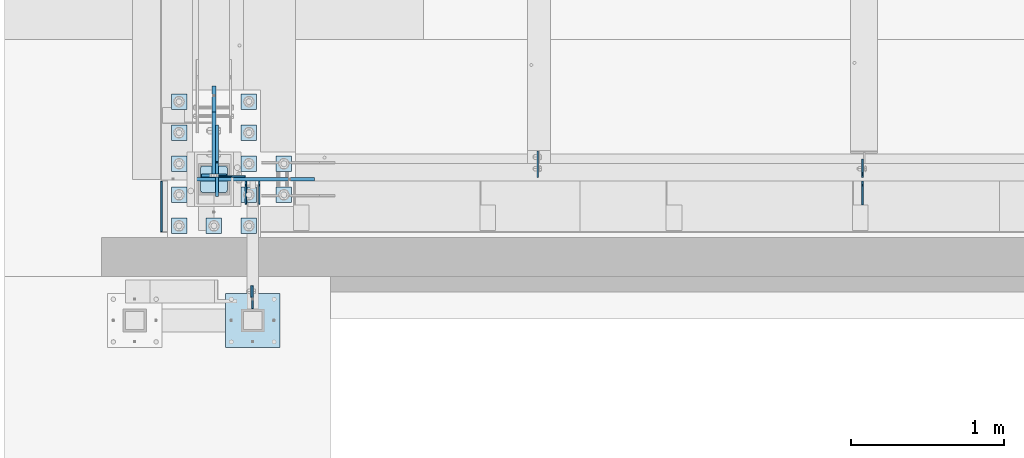
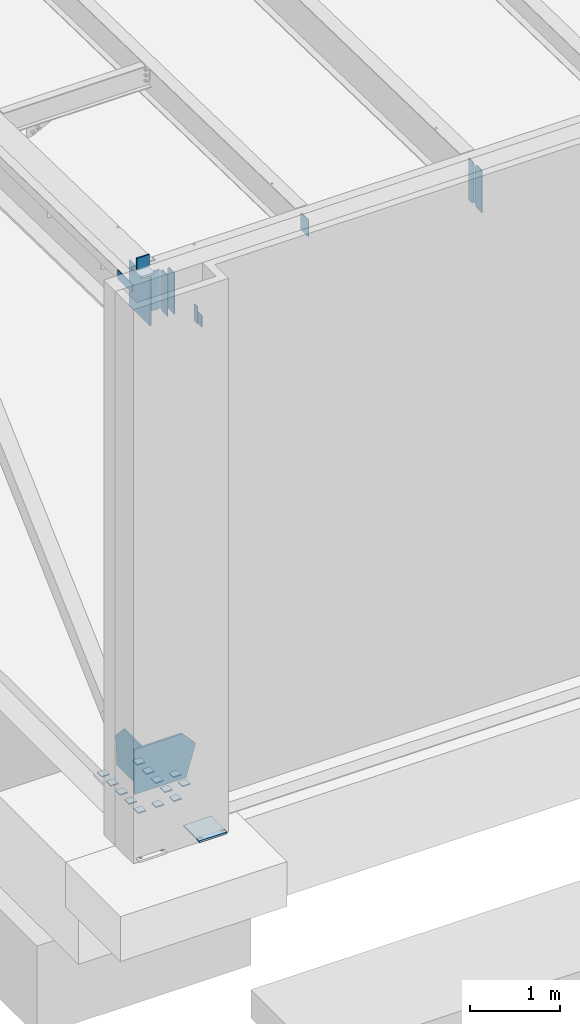
# One storey, part 1426 of 1763: 28 plates, 5 elements without a shape of their own.
"""IFC2X3 building model written with IfcOpenShell, lengths in millimetres."""

import ifcopenshell
import ifcopenshell.guid

model = None  # the IFC model being written
_history = None  # IfcOwnerHistory: only IFC2X3 demands one
_inside = {}  # id of a spatial element -> (the spatial element, [elements in it])
_under = {}  # id of a project, library or spatial element -> (it, [spatial elements below it])
_declared = {}  # id of a project -> (the project, [libraries it declares])
_typed = {}  # id of a type object -> (the type object, [elements of that type])
_made_of = {}  # id of a material, layer set ... -> (it, [elements and type objects made of it])


def new_model(schema):
    """Start an empty IFC model of exactly this schema.

    Asked for "IFC4X3", IfcOpenShell would pick the latest addendum, in which some entities
    have other attributes; the version numbers below select the first issue.
    IFC2X3 requires an IfcOwnerHistory on every rooted entity: one is made here for all.
    """
    global model, _history
    if schema == "IFC4X3":
        model = ifcopenshell.file(schema_version=(4, 3, 0, 0))
    else:
        model = ifcopenshell.file(schema=schema)
    _inside.clear()
    _under.clear()
    _declared.clear()
    _typed.clear()
    _made_of.clear()
    _history = None
    if model.schema == "IFC2X3":
        org = make("IfcOrganization", Name="unknown")
        user = make(
            "IfcPersonAndOrganization",
            ThePerson=make("IfcPerson", FamilyName="unknown"),
            TheOrganization=org,
        )
        app = make(
            "IfcApplication",
            ApplicationDeveloper=org,
            Version="unknown",
            ApplicationFullName="unknown",
            ApplicationIdentifier="unknown",
        )
        _history = make(
            "IfcOwnerHistory",
            OwningUser=user,
            OwningApplication=app,
            ChangeAction="ADDED",
            CreationDate=0,
        )
    return model


def make(cls, **values):
    """One entity of the class cls with the attributes given. An attribute that is None is left unset."""
    return model.create_entity(
        cls, **{name: value for name, value in values.items() if value is not None}
    )


def rooted(cls, **values):
    """An entity with a GlobalId (a new one), such as an element, a storey or a relation."""
    return make(cls, GlobalId=ifcopenshell.guid.new(), OwnerHistory=_history, **values)


def si_unit(unit_type, name, prefix=None):
    """IfcSIUnit, for example si_unit("LENGTHUNIT", "METRE", prefix="MILLI")."""
    return make("IfcSIUnit", UnitType=unit_type, Prefix=prefix, Name=name)


def assignment(units):
    """IfcUnitAssignment: the units of a project."""
    return None if units is None else make("IfcUnitAssignment", Units=units)


def point(xyz):
    """IfcCartesianPoint."""
    return None if xyz is None else make("IfcCartesianPoint", Coordinates=xyz)


def direction(xyz):
    """IfcDirection."""
    return None if xyz is None else make("IfcDirection", DirectionRatios=xyz)


def frame(location, z_axis=None, x_axis=None):
    """IfcAxis2Placement3D, a coordinate frame: its origin and axes. An axis left out is left unset."""
    return make(
        "IfcAxis2Placement3D",
        Location=point(location),
        Axis=direction(z_axis),
        RefDirection=direction(x_axis),
    )


def origin_with_axes():
    """The frame at (0, 0, 0) with the z axis (0, 0, 1) and the x axis (1, 0, 0) written out."""
    return frame((0.0, 0.0, 0.0), z_axis=(0.0, 0.0, 1.0), x_axis=(1.0, 0.0, 0.0))


def place(relative_to, where):
    """IfcLocalPlacement: puts the frame where relative to a parent placement (None: the world)."""
    return make(
        "IfcLocalPlacement", PlacementRelTo=relative_to, RelativePlacement=where
    )


def context(
    kind, dimensions, precision=None, world=None, true_north=None, identifier=None
):
    """IfcGeometricRepresentationContext, for example the 3D "Model" context."""
    return make(
        "IfcGeometricRepresentationContext",
        ContextIdentifier=identifier,
        ContextType=kind,
        CoordinateSpaceDimension=dimensions,
        Precision=precision,
        WorldCoordinateSystem=world,
        TrueNorth=true_north,
    )


def subcontext(parent, identifier, kind, view, scale=None):
    """IfcGeometricRepresentationSubContext, for example "Body" below "Model"."""
    return make(
        "IfcGeometricRepresentationSubContext",
        ContextIdentifier=identifier,
        ContextType=kind,
        ParentContext=parent,
        TargetScale=scale,
        TargetView=view,
    )


def project(units=None, contexts=None):
    """IfcProject with its units and contexts."""
    return rooted(
        "IfcProject",
        Name="project",
        RepresentationContexts=contexts,
        UnitsInContext=assignment(units),
    )


def spatial(cls, under=None, at=None, **own):
    """A site, building, storey or space (cls), placed at a placement, below another one or the project."""
    s = rooted(cls, ObjectPlacement=at, **own)
    if under is not None:
        _under.setdefault(under.id(), (under, []))[1].append(s)
    return s


def faces_of(points, faces, orient=None, outer=None):
    """IfcFace entities. A face is a list of loops; a loop is a list of indices into points, from 0.

    orient and outer hold one flag for each loop. By default every Orientation is true, the
    first loop of a face is its IfcFaceOuterBound and the others are IfcFaceBound.
    """
    made = []
    for i, loops in enumerate(faces):
        bounds = []
        for j, loop in enumerate(loops):
            is_outer = j == 0 if outer is None else outer[i][j]
            bounds.append(
                make(
                    "IfcFaceOuterBound" if is_outer else "IfcFaceBound",
                    Bound=make("IfcPolyLoop", Polygon=[points[k] for k in loop]),
                    Orientation=True if orient is None else orient[i][j],
                )
            )
        made.append(make("IfcFace", Bounds=bounds))
    return made


def faceted_brep(points, faces, orient=None, outer=None, voids=None):
    """IfcFacetedBrep: a solid bounded by flat faces; with voids (closed shells), ...WithVoids."""
    shared = [point(p) for p in points]
    hull = make("IfcClosedShell", CfsFaces=faces_of(shared, faces, orient, outer))
    if voids is None:
        return make("IfcFacetedBrep", Outer=hull)
    return make(
        "IfcFacetedBrepWithVoids",
        Outer=hull,
        Voids=[
            make(cls, CfsFaces=faces_of(shared, fs, o, b)) for cls, fs, o, b in voids
        ],
    )


def shape(context_of_items, identifier, shape_type, items):
    """IfcShapeRepresentation: the items that make up one representation, for example the "Body"."""
    return make(
        "IfcShapeRepresentation",
        ContextOfItems=context_of_items,
        RepresentationIdentifier=identifier,
        RepresentationType=shape_type,
        Items=items,
    )


def material(Name=None, Category=None):
    """IfcMaterial."""
    return make("IfcMaterial", Name=Name, Category=Category)


def made_of(thing, what):
    """Note that an element or type object is made of a material, layer set ...; save() writes the relation."""
    if what is not None:
        _made_of.setdefault(what.id(), (what, []))[1].append(thing)
    return thing


def type_object(cls, material=None, **own):
    """A type object (cls), such as IfcWallType, which elements share."""
    return made_of(rooted(cls, **own), material)


def element(
    cls,
    number,
    at=None,
    inside=None,
    cuts=None,
    type_object=None,
    material=None,
    context=None,
    identifier="Body",
    shape_type=None,
    held_by="IfcProductDefinitionShape",
    body=None,
    shapes=None,
    **own,
):
    """One element of the class cls, such as IfcWall. Its Tag is "e" and its number.

    at: its placement. inside: the storey or other place that contains it. cuts: it is an
    opening in that element (IfcRelVoidsElement). A single representation is given by context,
    identifier, shape_type and body (its items); several are given by shapes. held_by: the class
    of the entity that holds the representations. save() writes the other relations.
    """
    e = rooted(cls, Tag="e%d" % number, ObjectPlacement=at, **own)
    if body is not None:
        shapes = [shape(context, identifier, shape_type, body)]
    if shapes is not None:
        e.Representation = make(held_by, Representations=shapes)
    if inside is not None:
        _inside.setdefault(inside.id(), (inside, []))[1].append(e)
    if cuts is not None:
        rooted(
            "IfcRelVoidsElement", RelatingBuildingElement=cuts, RelatedOpeningElement=e
        )
    if type_object is not None:
        _typed.setdefault(type_object.id(), (type_object, []))[1].append(e)
    return made_of(e, material)


def aggregate(whole, parts):
    """IfcRelAggregates: a whole, such as a stair, and the parts it consists of."""
    return rooted("IfcRelAggregates", RelatingObject=whole, RelatedObjects=parts)


def save(model, path):
    """Write the relations noted so far, then the file.

    IfcRelAggregates (storeys below a building ...), IfcRelContainedInSpatialStructure (elements
    in a storey), IfcRelDefinesByType, IfcRelAssociatesMaterial and IfcRelDeclares: one each for
    every whole, place, type object, material and project.
    """
    for whole, parts in _under.values():
        aggregate(whole, parts)
    for where, things in _inside.values():
        rooted(
            "IfcRelContainedInSpatialStructure",
            RelatedElements=things,
            RelatingStructure=where,
        )
    for kind, things in _typed.values():
        rooted("IfcRelDefinesByType", RelatedObjects=things, RelatingType=kind)
    for what, things in _made_of.values():
        rooted("IfcRelAssociatesMaterial", RelatedObjects=things, RelatingMaterial=what)
    for by, libraries in _declared.values():
        rooted("IfcRelDeclares", RelatingContext=by, RelatedDefinitions=libraries)
    model.write(path)


model = new_model("IFC2X3")

# Units and contexts
model_context = context("Model", 3, precision=1e-05, world=origin_with_axes())
body_context = subcontext(model_context, "Body", "Model", "MODEL_VIEW")
ifc_project = project(units=[si_unit("LENGTHUNIT", "METRE", prefix="MILLI"), si_unit("AREAUNIT", "SQUARE_METRE"), si_unit("VOLUMEUNIT", "CUBIC_METRE"), si_unit("MASSUNIT", "GRAM", prefix="KILO"), si_unit("TIMEUNIT", "SECOND"), si_unit("PLANEANGLEUNIT", "RADIAN"), si_unit("SOLIDANGLEUNIT", "STERADIAN"), si_unit("THERMODYNAMICTEMPERATUREUNIT", "DEGREE_CELSIUS"), si_unit("LUMINOUSINTENSITYUNIT", "LUMEN")], contexts=[model_context])

# Site, building, storey
site_placement = place(None, origin_with_axes())
site = spatial("IfcSite", under=ifc_project, at=site_placement, CompositionType="ELEMENT")
building_placement = place(site_placement, origin_with_axes())
building = spatial("IfcBuilding", under=site, at=building_placement, Name="Undefined", CompositionType="ELEMENT")
storey_placement = place(building_placement, origin_with_axes())
storey = spatial("IfcBuildingStorey", under=building, at=storey_placement, Name="Undefined", CompositionType="ELEMENT", Elevation=0.0)

# Assembly, plate
assembly_1_placement = place(storey_placement, origin_with_axes())
assembly_1 = element("IfcElementAssembly", 1, at=assembly_1_placement, inside=storey, Name="BEAM", AssemblyPlace="NOTDEFINED", PredefinedType="RIGID_FRAME")
ifc_material_1 = material(Name="STEEL/A36")
plate_type_1 = type_object("IfcPlateType", PredefinedType="NOTDEFINED")
plate_1_placement = place(assembly_1_placement, frame((-87131.5061245708, -14487.5249884881, 11849.0999938965), z_axis=(0.0, 0.0, 1.0), x_axis=(0.0, 1.0, 0.0)))
plate_1 = element("IfcPlate", 2, at=plate_1_placement, type_object=plate_type_1, material=ifc_material_1, Name="PLATE", context=body_context, shape_type="Brep", body=[
    faceted_brep([(0.0, -4.76249999999982, 0.0), (-2.83762346953154e-10, -4.7624999996915, 228.600006103516), (-2.83762346953154e-10, 4.76250000028813, 228.600006103517), (0.0, 4.76249999999982, 0.0), (76.1999969480166, -4.76249999961874, 228.600006103516), (76.1999969480166, 4.76250000036089, 228.600006103517), (76.1999969482931, -4.76249999991705, 0.0), (76.1999969482931, 4.76250000006257, 1.81898940354586e-12)], [[[0, 1, 2, 3]], [[1, 4, 5, 2]], [[4, 6, 7, 5]], [[6, 0, 3, 7]], [[5, 7, 3, 2]], [[6, 4, 1, 0]]]),
])
aggregate(assembly_1, [plate_1])

# Assembly, plates
assembly_2_placement = place(storey_placement, origin_with_axes())
assembly_2 = element("IfcElementAssembly", 3, at=assembly_2_placement, inside=storey, Name="BEAM", AssemblyPlace="NOTDEFINED", PredefinedType="RIGID_FRAME")
plate_type_2 = type_object("IfcPlateType", PredefinedType="NOTDEFINED")
plate_2_placement = place(assembly_2_placement, frame((-87719.9247736984, -13728.6998186171, 12211.05), z_axis=(0.0, 0.0, 1.0), x_axis=(0.0, -1.0, 0.0)))
plate_2 = element("IfcPlate", 4, at=plate_2_placement, type_object=plate_type_2, material=ifc_material_1, Name="PLATE", context=body_context, shape_type="Brep", body=[
    faceted_brep([(0.0, -4.76249999999982, 0.0), (3.8198777474463e-11, -4.76249999978609, 120.649999999834), (3.45607986673713e-11, 4.76250000024447, 120.649999999841), (0.0, 4.76249999999982, 0.0), (330.200012207031, -4.76249999978609, 120.650001525879), (330.200012207031, 4.76250000021537, 120.650001525879), (330.200012207031, -4.76249999996799, 19.0499992370605), (330.200012207031, 4.76250000003347, 19.0499992370605), (311.150012969971, -4.76250000000073, 0.0), (311.150012969971, 4.76250000000073, 0.0)], [[[0, 1, 2, 3]], [[1, 4, 5, 2]], [[4, 6, 7, 5]], [[6, 8, 9, 7]], [[8, 0, 3, 9]], [[5, 7, 9, 3, 2]], [[8, 6, 4, 1, 0]]]),
])
plate_3_placement = place(assembly_2_placement, frame((-83132.2770593287, -13704.0935686171, 11590.3375), z_axis=(0.0, 0.0, 1.0), x_axis=(0.0, 1.0, 0.0)))
plate_3 = element("IfcPlate", 5, at=plate_3_placement, type_object=plate_type_2, material=ifc_material_1, Name="PLATE", context=body_context, shape_type="Brep", body=[
    faceted_brep([(0.0, -4.76250000000073, 31.75), (0.0, -4.76250000000073, 538.162475585938), (0.0, 4.76250000000073, 538.162475585938), (0.0, 4.76250000000073, 31.75), (31.75, -4.76250000000073, 569.912475585938), (31.75, 4.76250000000073, 569.912475585938), (120.650001525879, -4.76249999999709, 569.912475585938), (120.650001525879, 4.76249999999709, 569.912475585938), (120.650001525879, -4.76249999999709, 0.0), (120.650001525879, 4.76249999999709, 0.0), (31.75, -4.76250000000073, 0.0), (31.75, 4.76250000000073, 0.0)], [[[0, 1, 2, 3]], [[1, 4, 5, 2]], [[4, 6, 7, 5]], [[6, 8, 9, 7]], [[8, 10, 11, 9]], [[10, 0, 3, 11]], [[5, 7, 9, 11, 3, 2]], [[10, 8, 6, 4, 1, 0]]]),
])

# Assembly, plate
assembly_3_placement = place(storey_placement, origin_with_axes())
assembly_3 = element("IfcElementAssembly", 6, at=assembly_3_placement, inside=storey, Name="FRAME", AssemblyPlace="NOTDEFINED", PredefinedType="RIGID_FRAME")
plate_type_3 = type_object("IfcPlateType", PredefinedType="NOTDEFINED")
plate_4_placement = place(assembly_3_placement, frame((-87121.9811260709, -14411.3249944297, 12001.499987793), z_axis=(0.0, 0.0, -1.0), x_axis=(0.0, -1.0, 0.0)))
plate_4 = element("IfcPlate", 7, at=plate_4_placement, type_object=plate_type_3, material=ifc_material_1, Name="PLATE", context=body_context, shape_type="Brep", body=[
    faceted_brep([(0.0, -4.76249999999982, 0.0), (-3.05175672110636e-06, -4.7625000002663, 152.399993896484), (-3.05175490211695e-06, 4.76249999972788, 152.399993896484), (0.0, 4.76249999999982, 0.0), (152.400009155272, -4.76249999975698, 152.399993896484), (152.400009155273, 4.76250000024447, 152.399993896484), (152.400009155272, -4.76249999948777, 5.45696821063757e-12), (152.400009155273, 4.76250000051368, 3.63797880709171e-12)], [[[0, 1, 2, 3]], [[1, 4, 5, 2]], [[4, 6, 7, 5]], [[6, 0, 3, 7]], [[5, 7, 3, 2]], [[6, 4, 1, 0]]]),
])

# Plate
plate_5_placement = place(assembly_2_placement, frame((-87166.4311228712, -13880.3060686171, 11590.3375), z_axis=(0.0, 0.0, 1.0), x_axis=(0.0, 1.0, 0.0)))
plate_5 = element("IfcPlate", 8, at=plate_5_placement, type_object=plate_type_3, material=ifc_material_1, Name="PLATE", context=body_context, shape_type="Brep", body=[
    faceted_brep([(0.0, -4.76249999999982, 0.0), (0.0, -4.76250000012806, 568.325012206604), (0.0, 4.7624999999025, 568.325012206606), (0.0, 4.76249999999982, 0.0), (120.649993896484, -4.76250000000073, 568.325012207031), (120.649993896484, 4.76250000000073, 568.325012207031), (152.399993896484, -4.76250000000073, 536.575012207031), (152.399993896484, 4.76250000000073, 536.575012207031), (152.399993896484, -4.76250000000073, 31.75), (152.399993896484, 4.76250000000073, 31.75), (120.650001525879, -4.76249999999709, 0.0), (120.650001525879, 4.76249999999709, 0.0)], [[[0, 1, 2, 3]], [[1, 4, 5, 2]], [[4, 6, 7, 5]], [[6, 8, 9, 7]], [[8, 10, 11, 9]], [[10, 0, 3, 11]], [[5, 7, 9, 11, 3, 2]], [[10, 8, 6, 4, 1, 0]]]),
])

plate_6_placement = place(assembly_2_placement, frame((-87079.1186228712, -13880.3060686171, 11590.3375), z_axis=(0.0, 0.0, 1.0), x_axis=(0.0, 1.0, 0.0)))
plate_6 = element("IfcPlate", 9, at=plate_6_placement, type_object=plate_type_3, material=ifc_material_1, Name="PLATE", context=body_context, shape_type="Brep", body=[
    faceted_brep([(0.0, -4.76249999999982, 0.0), (0.0, -4.76250000012806, 568.325012206604), (0.0, 4.7624999999025, 568.325012206606), (0.0, 4.76249999999982, 0.0), (120.649993896484, -4.76250000000073, 568.325012207031), (120.649993896484, 4.76250000000073, 568.325012207031), (152.399993896484, -4.76250000000073, 536.575012207031), (152.399993896484, 4.76250000000073, 536.575012207031), (152.399993896484, -4.76250000000073, 31.75), (152.399993896484, 4.76250000000073, 31.75), (120.650001525879, -4.76249999999709, 0.0), (120.650001525879, 4.76249999999709, 0.0)], [[[0, 1, 2, 3]], [[1, 4, 5, 2]], [[4, 6, 7, 5]], [[6, 8, 9, 7]], [[8, 10, 11, 9]], [[10, 0, 3, 11]], [[5, 7, 9, 11, 3, 2]], [[10, 8, 6, 4, 1, 0]]]),
])

plate_type_4 = type_object("IfcPlateType", PredefinedType="NOTDEFINED")
plate_7_placement = place(assembly_3_placement, frame((-87299.7811228713, -14462.125, 5080.0), z_axis=(1.0, 0.0, 0.0), x_axis=(0.0, -1.0, 0.0)))
plate_7 = element("IfcPlate", 10, at=plate_7_placement, type_object=plate_type_4, material=ifc_material_1, Name="PLATE", context=body_context, shape_type="Brep", body=[
    faceted_brep([(0.0, -12.6999999999971, -1.81898940354586e-12), (0.0, -12.6999999999998, 355.600006103516), (0.0, 12.6999999999998, 355.600006103516), (0.0, 12.6999999999971, -1.81898940354586e-12), (355.600006103516, -12.6999999999998, 355.600006103516), (355.600006103516, 12.6999999999998, 355.600006103516), (355.600006103516, -12.6999999999998, 0.0), (355.600006103516, 12.6999999999998, 0.0)], [[[0, 1, 2, 3]], [[1, 4, 5, 2]], [[4, 6, 7, 5]], [[6, 0, 3, 7]], [[5, 7, 3, 2]], [[6, 4, 1, 0]]]),
])

aggregate(assembly_3, [plate_4, plate_7])

# Assembly, plates
assembly_4_placement = place(storey_placement, origin_with_axes())
assembly_4 = element("IfcElementAssembly", 11, at=assembly_4_placement, inside=storey, Name="TEMPLATE", AssemblyPlace="NOTDEFINED", PredefinedType="RIGID_FRAME")
plate_type_5 = type_object("IfcPlateType", PredefinedType="NOTDEFINED")
plate_8_placement = place(assembly_4_placement, frame((-87553.2372736983, -13970.0, 5138.73750000001), z_axis=(-1.0, 0.0, 0.0), x_axis=(0.0, -1.0, 0.0)))
plate_8 = element("IfcPlate", 12, at=plate_8_placement, type_object=plate_type_5, material=ifc_material_1, Name="WASHER PLATE", context=body_context, shape_type="Brep", body=[
    faceted_brep([(-7.27595761418343e-12, -7.9375, 0.0), (0.0, -7.9375, 101.599998474121), (0.0, 7.9375, 101.599998474121), (-7.27595761418343e-12, 7.9375, 0.0), (101.599998474121, -7.9375, 101.599998474121), (101.599998474121, 7.9375, 101.599998474121), (101.599998474121, -7.9375, 0.0), (101.599998474121, 7.9375, 0.0)], [[[0, 1, 2, 3]], [[1, 4, 5, 2]], [[4, 6, 7, 5]], [[6, 0, 3, 7]], [[5, 7, 3, 2]], [[6, 4, 1, 0]]]),
])
plate_9_placement = place(assembly_4_placement, frame((-87324.6372736983, -13970.0, 5138.73750000001), z_axis=(-1.0, 0.0, 0.0), x_axis=(0.0, -1.0, 0.0)))
plate_9 = element("IfcPlate", 13, at=plate_9_placement, type_object=plate_type_5, material=ifc_material_1, Name="WASHER PLATE", context=body_context, shape_type="Brep", body=[
    faceted_brep([(-7.27595761418343e-12, -7.9375, 0.0), (0.0, -7.9375, 101.599998474121), (0.0, 7.9375, 101.599998474121), (-7.27595761418343e-12, 7.9375, 0.0), (101.599998474121, -7.9375, 101.599998474121), (101.599998474121, 7.9375, 101.599998474121), (101.599998474121, -7.9375, 0.0), (101.599998474121, 7.9375, 0.0)], [[[0, 1, 2, 3]], [[1, 4, 5, 2]], [[4, 6, 7, 5]], [[6, 0, 3, 7]], [[5, 7, 3, 2]], [[6, 4, 1, 0]]]),
])
plate_10_placement = place(assembly_4_placement, frame((-87096.0372736983, -13970.0, 5138.73750000001), z_axis=(-1.0, 0.0, 0.0), x_axis=(0.0, -1.0, 0.0)))
plate_10 = element("IfcPlate", 14, at=plate_10_placement, type_object=plate_type_5, material=ifc_material_1, Name="WASHER PLATE", context=body_context, shape_type="Brep", body=[
    faceted_brep([(-7.27595761418343e-12, -7.9375, 0.0), (0.0, -7.9375, 101.599998474121), (0.0, 7.9375, 101.599998474121), (-7.27595761418343e-12, 7.9375, 0.0), (101.599998474121, -7.9375, 101.599998474121), (101.599998474121, 7.9375, 101.599998474121), (101.599998474121, -7.9375, 0.0), (101.599998474121, 7.9375, 0.0)], [[[0, 1, 2, 3]], [[1, 4, 5, 2]], [[4, 6, 7, 5]], [[6, 0, 3, 7]], [[5, 7, 3, 2]], [[6, 4, 1, 0]]]),
])
plate_11_placement = place(assembly_4_placement, frame((-87553.2372736983, -13766.8, 5138.73750000001), z_axis=(-1.0, 0.0, 0.0), x_axis=(0.0, -1.0, 0.0)))
plate_11 = element("IfcPlate", 15, at=plate_11_placement, type_object=plate_type_5, material=ifc_material_1, Name="WASHER PLATE", context=body_context, shape_type="Brep", body=[
    faceted_brep([(-7.27595761418343e-12, -7.9375, 0.0), (0.0, -7.9375, 101.599998474121), (0.0, 7.9375, 101.599998474121), (-7.27595761418343e-12, 7.9375, 0.0), (101.599998474121, -7.9375, 101.599998474121), (101.599998474121, 7.9375, 101.599998474121), (101.599998474121, -7.9375, 0.0), (101.599998474121, 7.9375, 0.0)], [[[0, 1, 2, 3]], [[1, 4, 5, 2]], [[4, 6, 7, 5]], [[6, 0, 3, 7]], [[5, 7, 3, 2]], [[6, 4, 1, 0]]]),
])
plate_12_placement = place(assembly_4_placement, frame((-87096.0372736983, -13766.8, 5138.73750000001), z_axis=(-1.0, 0.0, 0.0), x_axis=(0.0, -1.0, 0.0)))
plate_12 = element("IfcPlate", 16, at=plate_12_placement, type_object=plate_type_5, material=ifc_material_1, Name="WASHER PLATE", context=body_context, shape_type="Brep", body=[
    faceted_brep([(-7.27595761418343e-12, -7.9375, 0.0), (0.0, -7.9375, 101.599998474121), (0.0, 7.9375, 101.599998474121), (-7.27595761418343e-12, 7.9375, 0.0), (101.599998474121, -7.9375, 101.599998474121), (101.599998474121, 7.9375, 101.599998474121), (101.599998474121, -7.9375, 0.0), (101.599998474121, 7.9375, 0.0)], [[[0, 1, 2, 3]], [[1, 4, 5, 2]], [[4, 6, 7, 5]], [[6, 0, 3, 7]], [[5, 7, 3, 2]], [[6, 4, 1, 0]]]),
])
plate_13_placement = place(assembly_4_placement, frame((-86867.4372736983, -13766.8, 5138.73750000001), z_axis=(-1.0, 0.0, 0.0), x_axis=(0.0, -1.0, 0.0)))
plate_13 = element("IfcPlate", 17, at=plate_13_placement, type_object=plate_type_5, material=ifc_material_1, Name="WASHER PLATE", context=body_context, shape_type="Brep", body=[
    faceted_brep([(-7.27595761418343e-12, -7.9375, 0.0), (0.0, -7.9375, 101.599998474121), (0.0, 7.9375, 101.599998474121), (-7.27595761418343e-12, 7.9375, 0.0), (101.599998474121, -7.9375, 101.599998474121), (101.599998474121, 7.9375, 101.599998474121), (101.599998474121, -7.9375, 0.0), (101.599998474121, 7.9375, 0.0)], [[[0, 1, 2, 3]], [[1, 4, 5, 2]], [[4, 6, 7, 5]], [[6, 0, 3, 7]], [[5, 7, 3, 2]], [[6, 4, 1, 0]]]),
])
plate_14_placement = place(assembly_4_placement, frame((-87553.2372736983, -13563.6, 5138.73750000001), z_axis=(-1.0, 0.0, 0.0), x_axis=(0.0, -1.0, 0.0)))
plate_14 = element("IfcPlate", 18, at=plate_14_placement, type_object=plate_type_5, material=ifc_material_1, Name="WASHER PLATE", context=body_context, shape_type="Brep", body=[
    faceted_brep([(-7.27595761418343e-12, -7.9375, 0.0), (0.0, -7.9375, 101.599998474121), (0.0, 7.9375, 101.599998474121), (-7.27595761418343e-12, 7.9375, 0.0), (101.599998474121, -7.9375, 101.599998474121), (101.599998474121, 7.9375, 101.599998474121), (101.599998474121, -7.9375, 0.0), (101.599998474121, 7.9375, 0.0)], [[[0, 1, 2, 3]], [[1, 4, 5, 2]], [[4, 6, 7, 5]], [[6, 0, 3, 7]], [[5, 7, 3, 2]], [[6, 4, 1, 0]]]),
])
plate_15_placement = place(assembly_4_placement, frame((-87096.0372736983, -13563.6, 5138.73750000001), z_axis=(-1.0, 0.0, 0.0), x_axis=(0.0, -1.0, 0.0)))
plate_15 = element("IfcPlate", 19, at=plate_15_placement, type_object=plate_type_5, material=ifc_material_1, Name="WASHER PLATE", context=body_context, shape_type="Brep", body=[
    faceted_brep([(-7.27595761418343e-12, -7.9375, 0.0), (0.0, -7.9375, 101.599998474121), (0.0, 7.9375, 101.599998474121), (-7.27595761418343e-12, 7.9375, 0.0), (101.599998474121, -7.9375, 101.599998474121), (101.599998474121, 7.9375, 101.599998474121), (101.599998474121, -7.9375, 0.0), (101.599998474121, 7.9375, 0.0)], [[[0, 1, 2, 3]], [[1, 4, 5, 2]], [[4, 6, 7, 5]], [[6, 0, 3, 7]], [[5, 7, 3, 2]], [[6, 4, 1, 0]]]),
])
plate_16_placement = place(assembly_4_placement, frame((-86867.4372736983, -13563.6, 5138.73750000001), z_axis=(-1.0, 0.0, 0.0), x_axis=(0.0, -1.0, 0.0)))
plate_16 = element("IfcPlate", 20, at=plate_16_placement, type_object=plate_type_5, material=ifc_material_1, Name="WASHER PLATE", context=body_context, shape_type="Brep", body=[
    faceted_brep([(-7.27595761418343e-12, -7.9375, 0.0), (0.0, -7.9375, 101.599998474121), (0.0, 7.9375, 101.599998474121), (-7.27595761418343e-12, 7.9375, 0.0), (101.599998474121, -7.9375, 101.599998474121), (101.599998474121, 7.9375, 101.599998474121), (101.599998474121, -7.9375, 0.0), (101.599998474121, 7.9375, 0.0)], [[[0, 1, 2, 3]], [[1, 4, 5, 2]], [[4, 6, 7, 5]], [[6, 0, 3, 7]], [[5, 7, 3, 2]], [[6, 4, 1, 0]]]),
])
plate_17_placement = place(assembly_4_placement, frame((-87553.2372736983, -13360.4, 5138.73750000001), z_axis=(-1.0, 0.0, 0.0), x_axis=(0.0, -1.0, 0.0)))
plate_17 = element("IfcPlate", 21, at=plate_17_placement, type_object=plate_type_5, material=ifc_material_1, Name="WASHER PLATE", context=body_context, shape_type="Brep", body=[
    faceted_brep([(-7.27595761418343e-12, -7.9375, 0.0), (0.0, -7.9375, 101.599998474121), (0.0, 7.9375, 101.599998474121), (-7.27595761418343e-12, 7.9375, 0.0), (101.599998474121, -7.9375, 101.599998474121), (101.599998474121, 7.9375, 101.599998474121), (101.599998474121, -7.9375, 0.0), (101.599998474121, 7.9375, 0.0)], [[[0, 1, 2, 3]], [[1, 4, 5, 2]], [[4, 6, 7, 5]], [[6, 0, 3, 7]], [[5, 7, 3, 2]], [[6, 4, 1, 0]]]),
])
plate_18_placement = place(assembly_4_placement, frame((-87096.0372736983, -13360.4, 5138.73750000001), z_axis=(-1.0, 0.0, 0.0), x_axis=(0.0, -1.0, 0.0)))
plate_18 = element("IfcPlate", 22, at=plate_18_placement, type_object=plate_type_5, material=ifc_material_1, Name="WASHER PLATE", context=body_context, shape_type="Brep", body=[
    faceted_brep([(-7.27595761418343e-12, -7.9375, 0.0), (0.0, -7.9375, 101.599998474121), (0.0, 7.9375, 101.599998474121), (-7.27595761418343e-12, 7.9375, 0.0), (101.599998474121, -7.9375, 101.599998474121), (101.599998474121, 7.9375, 101.599998474121), (101.599998474121, -7.9375, 0.0), (101.599998474121, 7.9375, 0.0)], [[[0, 1, 2, 3]], [[1, 4, 5, 2]], [[4, 6, 7, 5]], [[6, 0, 3, 7]], [[5, 7, 3, 2]], [[6, 4, 1, 0]]]),
])
plate_19_placement = place(assembly_4_placement, frame((-87553.2372736983, -13157.2, 5138.73750000001), z_axis=(-1.0, 0.0, 0.0), x_axis=(0.0, -1.0, 0.0)))
plate_19 = element("IfcPlate", 23, at=plate_19_placement, type_object=plate_type_5, material=ifc_material_1, Name="WASHER PLATE", context=body_context, shape_type="Brep", body=[
    faceted_brep([(-7.27595761418343e-12, -7.9375, 0.0), (0.0, -7.9375, 101.599998474121), (0.0, 7.9375, 101.599998474121), (-7.27595761418343e-12, 7.9375, 0.0), (101.599998474121, -7.9375, 101.599998474121), (101.599998474121, 7.9375, 101.599998474121), (101.599998474121, -7.9375, 0.0), (101.599998474121, 7.9375, 0.0)], [[[0, 1, 2, 3]], [[1, 4, 5, 2]], [[4, 6, 7, 5]], [[6, 0, 3, 7]], [[5, 7, 3, 2]], [[6, 4, 1, 0]]]),
])
plate_20_placement = place(assembly_4_placement, frame((-87096.0372736983, -13157.2, 5138.73750000001), z_axis=(-1.0, 0.0, 0.0), x_axis=(0.0, -1.0, 0.0)))
plate_20 = element("IfcPlate", 24, at=plate_20_placement, type_object=plate_type_5, material=ifc_material_1, Name="WASHER PLATE", context=body_context, shape_type="Brep", body=[
    faceted_brep([(-7.27595761418343e-12, -7.9375, 0.0), (0.0, -7.9375, 101.599998474121), (0.0, 7.9375, 101.599998474121), (-7.27595761418343e-12, 7.9375, 0.0), (101.599998474121, -7.9375, 101.599998474121), (101.599998474121, 7.9375, 101.599998474121), (101.599998474121, -7.9375, 0.0), (101.599998474121, 7.9375, 0.0)], [[[0, 1, 2, 3]], [[1, 4, 5, 2]], [[4, 6, 7, 5]], [[6, 0, 3, 7]], [[5, 7, 3, 2]], [[6, 4, 1, 0]]]),
])
aggregate(assembly_4, [plate_8, plate_9, plate_10, plate_11, plate_12, plate_13, plate_14, plate_15, plate_16, plate_17, plate_18, plate_19, plate_20])

assembly_5_placement = place(storey_placement, origin_with_axes())
assembly_5 = element("IfcElementAssembly", 25, at=assembly_5_placement, inside=storey, Name="COLUMN", AssemblyPlace="NOTDEFINED", PredefinedType="RIGID_FRAME")
ifc_material_2 = material(Name="STEEL/A572-50")
plate_type_6 = type_object("IfcPlateType", PredefinedType="NOTDEFINED")
plate_21_placement = place(assembly_5_placement, frame((-87292.8872721725, -13690.5998186171, 12369.7999938965), z_axis=(0.0, 0.0, -1.0), x_axis=(-1.0, 0.0, 0.0)))
plate_21 = element("IfcPlate", 26, at=plate_21_placement, type_object=plate_type_6, material=ifc_material_2, Name="PLATE", context=body_context, shape_type="Brep", body=[
    faceted_brep([(7.27595761418343e-12, 9.52500000000146, 155.574990844727), (-1.45519152283669e-11, 7.27595761418343e-12, 165.099990844727), (165.099990844727, 0.0, 165.099990844727), (165.099990844727, 9.52500000000146, 155.574990844727), (-3.63797880709171e-11, -9.5249999999869, 155.574990844727), (165.099990844727, -9.52500000000146, 155.574990844727), (0.0, 9.52500000000146, 0.0), (0.0, -9.52500000000146, 0.0), (165.099990844727, -9.52500000000146, 0.0), (165.099990844727, 9.52500000000146, 0.0)], [[[0, 1, 2, 3]], [[1, 4, 5, 2]], [[6, 7, 4, 1, 0]], [[5, 8, 9, 3, 2]], [[8, 7, 6, 9]], [[9, 6, 0, 3]], [[7, 8, 5, 4]]]),
])
plate_type_7 = type_object("IfcPlateType", PredefinedType="NOTDEFINED")
plate_22_placement = place(assembly_5_placement, frame((-87288.1247736983, -13628.6875, 12172.95), z_axis=(0.0, -1.0, 0.0), x_axis=(-1.0, 0.0, 0.0)))
plate_22 = element("IfcPlate", 27, at=plate_22_placement, type_object=plate_type_7, material=ifc_material_1, Name="PLATE", context=body_context, shape_type="Brep", body=[
    faceted_brep([(-2.18278728425503e-11, -12.7000000000007, 15.875), (0.0, -12.7000000000007, 158.75), (0.0, 12.7000000000007, 158.75), (-2.18278728425503e-11, 12.7000000000007, 15.875), (1.20841242138704, -12.7000000000007, 164.825099488797), (1.20841242138704, 12.7000000000007, 164.825099488797), (4.6496798486769, -12.7000000000007, 169.975320151338), (4.6496798486769, 12.7000000000007, 169.975320151338), (9.79990051120694, -12.7000000000007, 173.416587578617), (9.79990051120694, 12.7000000000007, 173.416587578617), (15.875, -12.7000000000007, 174.625), (15.875, 12.7000000000007, 174.625), (158.75, -12.7000000000007, 174.625), (158.75, 12.7000000000007, 174.625), (164.825099488793, -12.7000000000007, 173.416587578617), (164.825099488793, 12.7000000000007, 173.416587578617), (169.975320151338, -12.7000000000007, 169.975320151336), (169.975320151338, 12.7000000000007, 169.975320151336), (173.416587578613, -12.7000000000007, 164.825099488797), (173.416587578613, 12.7000000000007, 164.825099488797), (174.625, -12.7000000000007, 158.75), (174.625, 12.7000000000007, 158.75), (174.625, -12.7000000000007, 15.8750000000073), (174.625, 12.7000000000007, 15.8750000000073), (173.416587578613, -12.7000000000007, 9.79990051121058), (173.416587578613, 12.7000000000007, 9.79990051121058), (169.975320151338, -12.7000000000007, 4.64967984866962), (169.975320151338, 12.7000000000007, 4.64967984866962), (164.825099488793, -12.7000000000007, 1.20841242139068), (164.825099488793, 12.7000000000007, 1.20841242139068), (158.75, -12.7000000000007, 7.27595761418343e-12), (158.75, 12.7000000000007, 7.27595761418343e-12), (15.8749999999854, -12.7000000000007, 0.0), (15.8749999999854, 12.7000000000007, 0.0), (9.79990051119239, -12.7000000000007, 1.20841242137976), (9.79990051119239, 12.7000000000007, 1.20841242137976), (4.64967984864779, -12.7000000000007, 4.64967984866234), (4.64967984864779, 12.7000000000007, 4.64967984866234), (1.20841242136521, -12.7000000000007, 9.79990051119967), (1.20841242136521, 12.7000000000007, 9.79990051119967)], [[[0, 1, 2, 3]], [[1, 4, 5, 2]], [[4, 6, 7, 5]], [[6, 8, 9, 7]], [[8, 10, 11, 9]], [[10, 12, 13, 11]], [[12, 14, 15, 13]], [[14, 16, 17, 15]], [[16, 18, 19, 17]], [[18, 20, 21, 19]], [[20, 22, 23, 21]], [[22, 24, 25, 23]], [[24, 26, 27, 25]], [[26, 28, 29, 27]], [[28, 30, 31, 29]], [[30, 32, 33, 31]], [[32, 34, 35, 33]], [[34, 36, 37, 35]], [[36, 38, 39, 37]], [[38, 0, 3, 39]], [[5, 7, 9, 11, 13, 15, 17, 19, 21, 23, 25, 27, 29, 31, 33, 35, 37, 39, 3, 2]], [[38, 36, 34, 32, 30, 28, 26, 24, 22, 20, 18, 16, 14, 12, 10, 8, 6, 4, 1, 0]]]),
])
plate_type_8 = type_object("IfcPlateType", PredefinedType="NOTDEFINED")
plate_23_placement = place(assembly_5_placement, frame((-87356.3872736984, -13608.05, 12159.4479542353), z_axis=(0.0, 0.0, -1.0), x_axis=(0.0, -1.0, 0.0)))
plate_23 = element("IfcPlate", 28, at=plate_23_placement, type_object=plate_type_8, material=ifc_material_2, Name="PLATE", context=body_context, shape_type="Brep", body=[
    faceted_brep([(-247.649993896484, -9.52499999999418, 46.037500000004), (-247.649993896484, 9.52499999999418, 46.037500000004), (-12.6999998092651, 9.52499999999418, 46.037500000004), (-12.6999998092651, -9.52499999999418, 46.037500000004), (-7.83992029121873, 9.52499999999418, 45.0707700774165), (-7.83992029121873, -9.52499999999418, 45.0707700774165), (-3.71974382306507, 9.52499999999418, 42.3177561769389), (-3.71974382306507, -9.52499999999418, 42.3177561769389), (-0.966729922587547, 9.52499999999418, 38.1975797087853), (-0.966729922587547, -9.52499999999418, 38.1975797087853), (0.0, -9.52499999999418, 33.3375001907389), (0.0, 9.52499999999418, 33.3375001907389), (0.0, 9.52500000000146, 0.0), (0.0, -9.52500000000146, 0.0), (-247.649993896484, -9.52499999999418, 655.637512207031), (222.25, -9.52499999999418, 655.637512207031), (222.25, 9.52499999999418, 655.637512207031), (-247.649993896484, 9.52499999999418, 655.637512207031), (222.25, -9.52499999999418, 0.0), (222.25, 9.52499999999418, 0.0)], [[[0, 1, 2, 3]], [[3, 2, 4, 5]], [[5, 4, 6, 7]], [[7, 6, 8, 9]], [[10, 11, 12, 13]], [[9, 8, 11, 10]], [[14, 15, 16, 17]], [[15, 18, 19, 16]], [[19, 18, 13, 12]], [[6, 4, 2, 1, 17, 16, 19, 12, 11, 8]], [[14, 17, 1, 0]], [[18, 15, 14, 0, 3, 5, 7, 9, 10, 13]]]),
])

# Plate
plate_type_9 = type_object("IfcPlateType", PredefinedType="NOTDEFINED")
plate_24_placement = place(assembly_2_placement, frame((-85257.0321665555, -13704.0935686171, 12127.0313376851), z_axis=(0.0, 1.0, 0.0), x_axis=(0.0, 0.0, -1.0)))
plate_24 = element("IfcPlate", 29, at=plate_24_placement, type_object=plate_type_9, material=ifc_material_1, Name="PLATE", context=body_context, shape_type="Brep", body=[
    faceted_brep([(0.0, -3.96900000000096, 0.0), (0.0, -3.96899999999732, 171.449996948242), (0.0, 3.96899999999732, 171.449996948242), (0.0, 3.96900000000096, 0.0), (228.600006103516, -3.96899999999732, 171.449996948242), (228.600006103516, 3.96899999999732, 171.449996948242), (228.600006103516, -3.96900000000096, 0.0), (228.600006103516, 3.96900000000096, 0.0)], [[[0, 1, 2, 3]], [[1, 4, 5, 2]], [[4, 6, 7, 5]], [[6, 0, 3, 7]], [[5, 7, 3, 2]], [[6, 4, 1, 0]]]),
])

plate_type_10 = type_object("IfcPlateType", PredefinedType="NOTDEFINED")
plate_25_placement = place(assembly_5_placement, frame((-87267.4872736983, -13699.3318193495, 12128.5), z_axis=(-1.0, 0.0, 0.0), x_axis=(0.0, 0.0, 1.0)))
plate_25 = element("IfcPlate", 30, at=plate_25_placement, type_object=plate_type_10, material=ifc_material_1, Name="PLATE", context=body_context, shape_type="Brep", body=[
    faceted_brep([(15.0812501907349, -4.76250000000073, 0.0), (9.30990560338796, -4.76250000000073, -1.14799181483977), (9.30990560338796, 4.76250000000073, -1.14799181483977), (15.0812501907349, 4.76250000000073, 0.0), (4.41719591209585, -4.76250000000073, -4.41719591210131), (4.41719591209585, 4.76250000000073, -4.41719591210131), (1.14799181483249, -4.76250000000073, -9.3099056033825), (1.14799181483249, 4.76250000000073, -9.3099056033825), (0.0, -4.76250000000073, -15.0812501907349), (0.0, 4.76250000000073, -15.0812501907349), (2.18278728425503e-11, -4.76249999967695, -95.2500000002037), (2.72848410531878e-11, 4.76250000027358, -95.2500000001892), (-533.400024414062, -4.76250000000073, -95.25), (-533.400024414062, 4.76250000000073, -95.25), (-533.400024414062, -4.76250000000073, 79.375), (-533.400024414062, 4.76250000000073, 79.375), (31.7499999999982, -4.76250000000073, 79.375), (31.7499999999982, 4.76250000000073, 79.375), (31.75, 4.76250000000073, 0.0), (31.75, -4.76250000000073, 0.0)], [[[0, 1, 2, 3]], [[1, 4, 5, 2]], [[4, 6, 7, 5]], [[6, 8, 9, 7]], [[8, 10, 11, 9]], [[10, 12, 13, 11]], [[12, 14, 15, 13]], [[15, 14, 16, 17]], [[3, 2, 5, 7, 9, 11, 13, 15, 17, 18]], [[0, 3, 18, 19]], [[14, 12, 10, 8, 6, 4, 1, 0, 19, 16]], [[18, 17, 16, 19]]]),
])

plate_type_11 = type_object("IfcPlateType", PredefinedType="NOTDEFINED")
plate_26_placement = place(assembly_2_placement, frame((-83132.2770593287, -13727.9060686171, 11588.75), z_axis=(0.0, 0.0, 1.0), x_axis=(0.0, -1.0, 0.0)))
plate_26 = element("IfcPlate", 31, at=plate_26_placement, type_object=plate_type_11, material=ifc_material_1, Name="PLATE", context=body_context, shape_type="Brep", body=[
    faceted_brep([(0.0, -4.76250000000073, 31.75), (0.0, -4.76250000000073, 539.75), (0.0, 4.76250000000073, 539.75), (0.0, 4.76250000000073, 31.75), (31.75, -4.76250000000073, 571.5), (31.75, 4.76250000000073, 571.5), (154.78125, -4.76250000000073, 571.5), (154.78125, 4.76250000000073, 571.5), (154.78125, -4.76250000000073, 0.0), (154.78125, 4.76250000000073, 0.0), (31.75, -4.76250000000073, 0.0), (31.75, 4.76250000000073, 0.0)], [[[0, 1, 2, 3]], [[1, 4, 5, 2]], [[4, 6, 7, 5]], [[6, 8, 9, 7]], [[8, 10, 11, 9]], [[10, 0, 3, 11]], [[5, 7, 9, 11, 3, 2]], [[10, 8, 6, 4, 1, 0]]]),
])

aggregate(assembly_2, [plate_5, plate_6, plate_2, plate_24, plate_26, plate_3])

ifc_material_3 = material(Name="STEEL/A572-GR.50")
plate_type_12 = type_object("IfcPlateType", PredefinedType="NOTDEFINED")
plate_27_placement = place(assembly_5_placement, frame((-87502.4372736983, -13716.0, 5130.80000000084), z_axis=(1.0, 0.0, 0.0), x_axis=(0.0, 0.0, 1.0)))
plate_27 = element("IfcPlate", 32, at=plate_27_placement, type_object=plate_type_12, material=ifc_material_3, Name="PLATE", context=body_context, shape_type="Brep", body=[
    faceted_brep([(0.0, -12.6999999999971, -1.81898940354586e-12), (0.0, -12.7000000000007, 660.400024414062), (0.0, 12.7000000000007, 660.400024414062), (0.0, 12.6999999999971, -1.81898940354586e-12), (423.419860839844, -12.7000000000007, 783.412475585938), (423.419860839844, 12.7000000000007, 783.412475585938), (611.640502929688, -12.7000000000007, 612.857543945312), (611.640502929688, 12.7000000000007, 612.857543945312), (611.640502929688, -12.7000000000007, 0.0), (611.640502929688, 12.7000000000007, 0.0)], [[[0, 1, 2, 3]], [[1, 4, 5, 2]], [[4, 6, 7, 5]], [[6, 8, 9, 7]], [[8, 0, 3, 9]], [[5, 7, 9, 3, 2]], [[8, 6, 4, 1, 0]]]),
])

plate_type_13 = type_object("IfcPlateType", PredefinedType="NOTDEFINED")
plate_28_placement = place(assembly_5_placement, frame((-87375.4372736983, -13703.3000000009, 5707.7998704001), z_axis=(0.0, 1.0, 0.0), x_axis=(0.0, 0.0, -1.0)))
plate_28 = element("IfcPlate", 33, at=plate_28_placement, type_object=plate_type_13, material=ifc_material_3, Name="PLATE", context=body_context, shape_type="Brep", body=[
    faceted_brep([(0.0, -12.6999999999971, -1.81898940354586e-12), (0.0, -12.6999999999971, 425.908142089844), (0.0, 12.6999999999971, 425.908142089844), (0.0, 12.6999999999971, -1.81898940354586e-12), (186.764999389648, -12.6999999999971, 598.055847167969), (186.764999389648, 12.6999999999971, 598.055847167969), (576.999877929688, -12.6999999999971, 571.5), (576.999877929688, 12.6999999999971, 571.5), (576.999877929688, -12.6999999999971, 1.81898940354586e-12), (576.999877929688, 12.6999999999971, 1.81898940354586e-12)], [[[0, 1, 2, 3]], [[1, 4, 5, 2]], [[4, 6, 7, 5]], [[6, 8, 9, 7]], [[8, 0, 3, 9]], [[5, 7, 9, 3, 2]], [[8, 6, 4, 1, 0]]]),
])

aggregate(assembly_5, [plate_21, plate_22, plate_25, plate_23, plate_28, plate_27])

save(model, "model.ifc")
